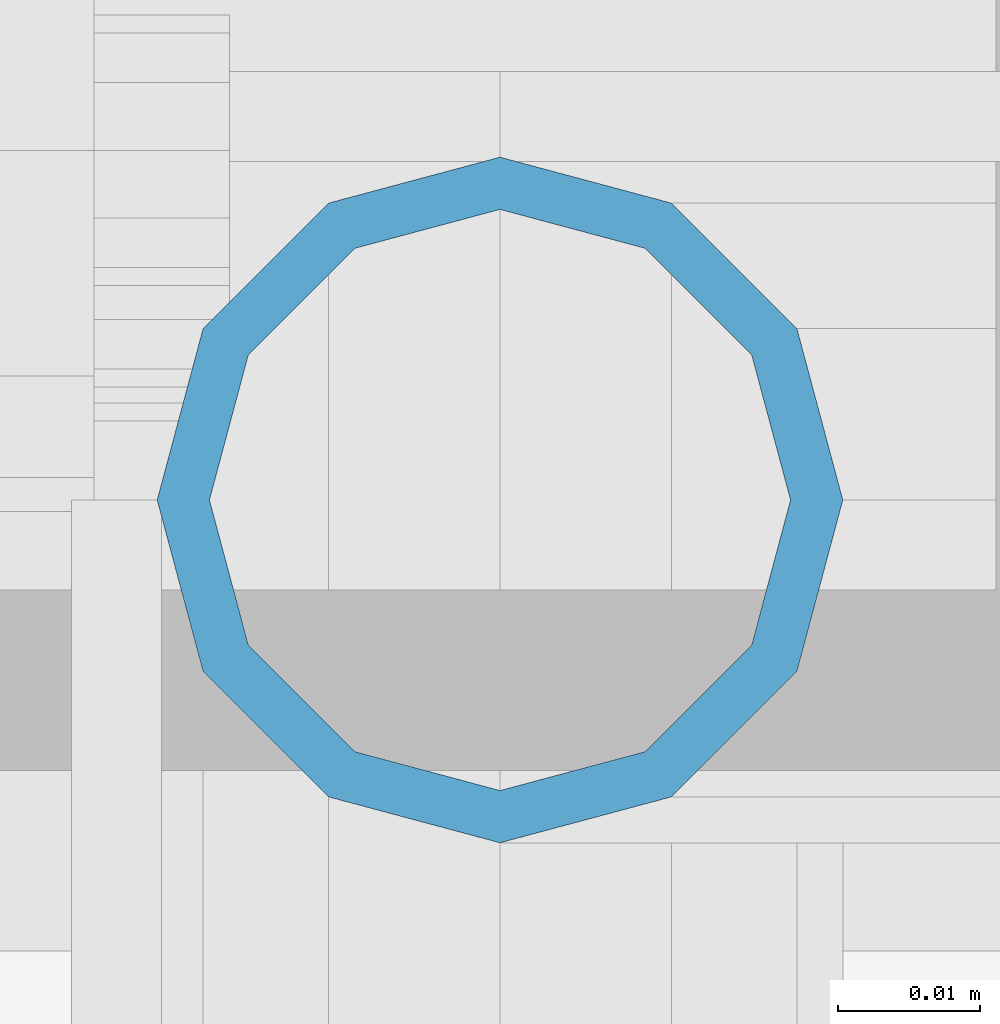
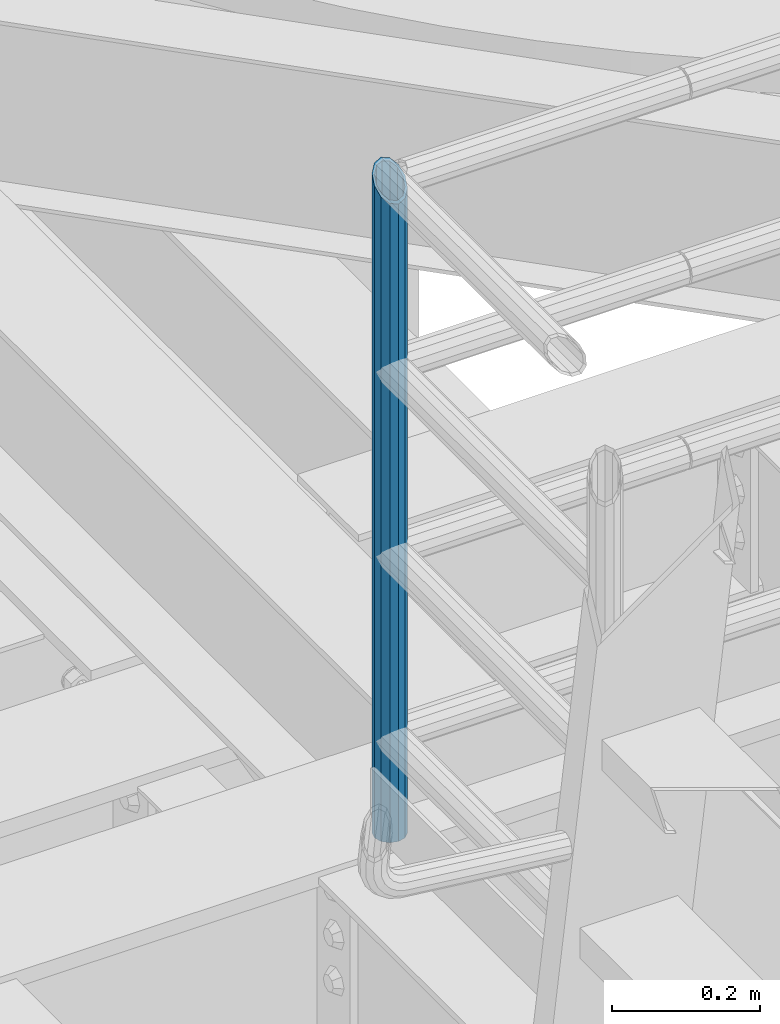
# One storey, part 607 of 1876: 1 column, 1 element without a shape of its own.
"""IFC2X3 building model written with IfcOpenShell, lengths in millimetres."""

from ifc_helpers import new_model, si_unit, frame, origin_with_axes, place, context, subcontext, project, spatial, faceted_brep, material, type_object, element, aggregate, save


model = new_model("IFC2X3")

# Units and contexts
model_context = context("Model", 3, precision=1e-05, world=origin_with_axes())
body_context = subcontext(model_context, "Body", "Model", "MODEL_VIEW")
ifc_project = project(units=[si_unit("LENGTHUNIT", "METRE", prefix="MILLI"), si_unit("AREAUNIT", "SQUARE_METRE"), si_unit("VOLUMEUNIT", "CUBIC_METRE"), si_unit("MASSUNIT", "GRAM", prefix="KILO"), si_unit("TIMEUNIT", "SECOND"), si_unit("PLANEANGLEUNIT", "RADIAN"), si_unit("SOLIDANGLEUNIT", "STERADIAN"), si_unit("THERMODYNAMICTEMPERATUREUNIT", "DEGREE_CELSIUS"), si_unit("LUMINOUSINTENSITYUNIT", "LUMEN")], contexts=[model_context])

# Site, building, storey
site_placement = place(None, origin_with_axes())
site = spatial("IfcSite", under=ifc_project, at=site_placement, CompositionType="ELEMENT")
building_placement = place(site_placement, origin_with_axes())
building = spatial("IfcBuilding", under=site, at=building_placement, Name="Undefined", CompositionType="ELEMENT")
storey_placement = place(building_placement, origin_with_axes())
storey = spatial("IfcBuildingStorey", under=building, at=storey_placement, Name="Undefined", CompositionType="ELEMENT", Elevation=0.0)

# Assembly, column
assembly_placement = place(storey_placement, origin_with_axes())
assembly = element("IfcElementAssembly", 1, at=assembly_placement, inside=storey, Name="RAIL", AssemblyPlace="NOTDEFINED", PredefinedType="RIGID_FRAME")
ifc_material = material()
column_type = type_object("IfcColumnType", Name="PIPE1-1/2SCH40", PredefinedType="NOTDEFINED")
column_placement = place(assembly_placement, frame((1781.175, -4654.55000114554, 17983.2), z_axis=(0.0, 1.0, 0.0), x_axis=(0.0, 0.0, 1.0)))
column = element("IfcColumn", 2, at=column_placement, type_object=column_type, material=ifc_material, Name="POST", ObjectType="PIPE1-1/2SCH40", context=body_context, shape_type="Brep", body=[
    faceted_brep([(0.0, -20.4469999999999, 0.0), (0.0, -17.7076214311803, 10.2235000000001), (1086.54849999999, -17.7076214311801, 10.2235000000001), (1076.325, -20.4469999999999, 0.0), (0.0, -10.2235000000001, 17.7076214311801), (1094.03262143117, -10.2235000000001, 17.7076214311801), (-1.45519152283669e-11, 0.0, 20.4470000000001), (1096.77199999999, 0.0, 20.4470000000001), (0.0, 10.2235000000001, 17.7076214311801), (1094.03262143117, 10.2235000000001, 17.7076214311801), (0.0, 17.7076214311803, 10.2235000000001), (1086.54849999999, 17.7076214311801, 10.2235000000001), (0.0, 20.4469999999999, 0.0), (1076.325, 20.4469999999999, 0.0), (0.0, 17.7076214311803, -10.2235000000001), (1066.10149999999, 17.7076214311801, -10.2235000000001), (0.0, 10.2235000000001, -17.7076214311801), (1058.61737856881, 10.2235000000001, -17.7076214311801), (-1.45519152283669e-11, 0.0, -20.4470000000001), (1055.87799999999, 0.0, -20.4470000000001), (0.0, -10.2235000000001, -17.7076214311801), (1058.61737856881, -10.2235000000001, -17.7076214311801), (0.0, -17.7076214311803, -10.2235000000001), (1066.10149999999, -17.7076214311801, -10.2235000000001), (0.0, -24.1299999999992, 0.0), (0.0, -20.8971929933184, -12.0649999999996), (1064.25999999999, -20.8971929933186, -12.0649999999996), (1076.325, -24.1300000000001, 0.0), (0.0, -12.0650000000001, -20.8971929933186), (1055.42780700667, -12.0649999999996, -20.8971929933186), (-1.45519152283669e-11, 0.0, -24.130000000001), (1052.19499999999, 0.0, -24.1300000000001), (0.0, 12.0650000000001, -20.8971929933186), (1055.42780700667, 12.0649999999996, -20.8971929933186), (0.0, 20.8971929933184, -12.0649999999996), (1064.25999999999, 20.8971929933186, -12.0649999999996), (0.0, 24.1299999999992, 0.0), (1076.325, 24.1300000000001, 0.0), (0.0, 20.8971929933184, 12.0649999999996), (1088.38999999999, 20.8971929933186, 12.0649999999996), (0.0, 12.0650000000001, 20.8971929933186), (1097.22219299331, 12.0649999999996, 20.8971929933186), (-1.45519152283669e-11, 0.0, 24.130000000001), (1100.45499999999, 0.0, 24.1300000000001), (0.0, -12.0650000000001, 20.8971929933186), (1097.22219299331, -12.0649999999996, 20.8971929933186), (0.0, -20.8971929933184, 12.0649999999996), (1088.38999999999, -20.8971929933186, 12.0649999999996)], [[[0, 1, 2, 3]], [[1, 4, 5, 2]], [[4, 6, 7, 5]], [[6, 8, 9, 7]], [[8, 10, 11, 9]], [[10, 12, 13, 11]], [[12, 14, 15, 13]], [[14, 16, 17, 15]], [[16, 18, 19, 17]], [[18, 20, 21, 19]], [[20, 22, 23, 21]], [[22, 0, 3, 23]], [[24, 25, 26, 27]], [[25, 28, 29, 26]], [[28, 30, 31, 29]], [[30, 32, 33, 31]], [[32, 34, 35, 33]], [[34, 36, 37, 35]], [[36, 38, 39, 37]], [[38, 40, 41, 39]], [[40, 42, 43, 41]], [[42, 44, 45, 43]], [[44, 46, 47, 45]], [[46, 24, 27, 47]], [[29, 31, 33, 35, 37, 39, 41, 43, 45, 47, 27, 26], [5, 7, 9, 11, 13, 15, 17, 19, 21, 23, 3, 2]], [[46, 44, 42, 40, 38, 36, 34, 32, 30, 28, 25, 24], [22, 20, 18, 16, 14, 12, 10, 8, 6, 4, 1, 0]]]),
])
aggregate(assembly, [column])

save(model, "model.ifc")
